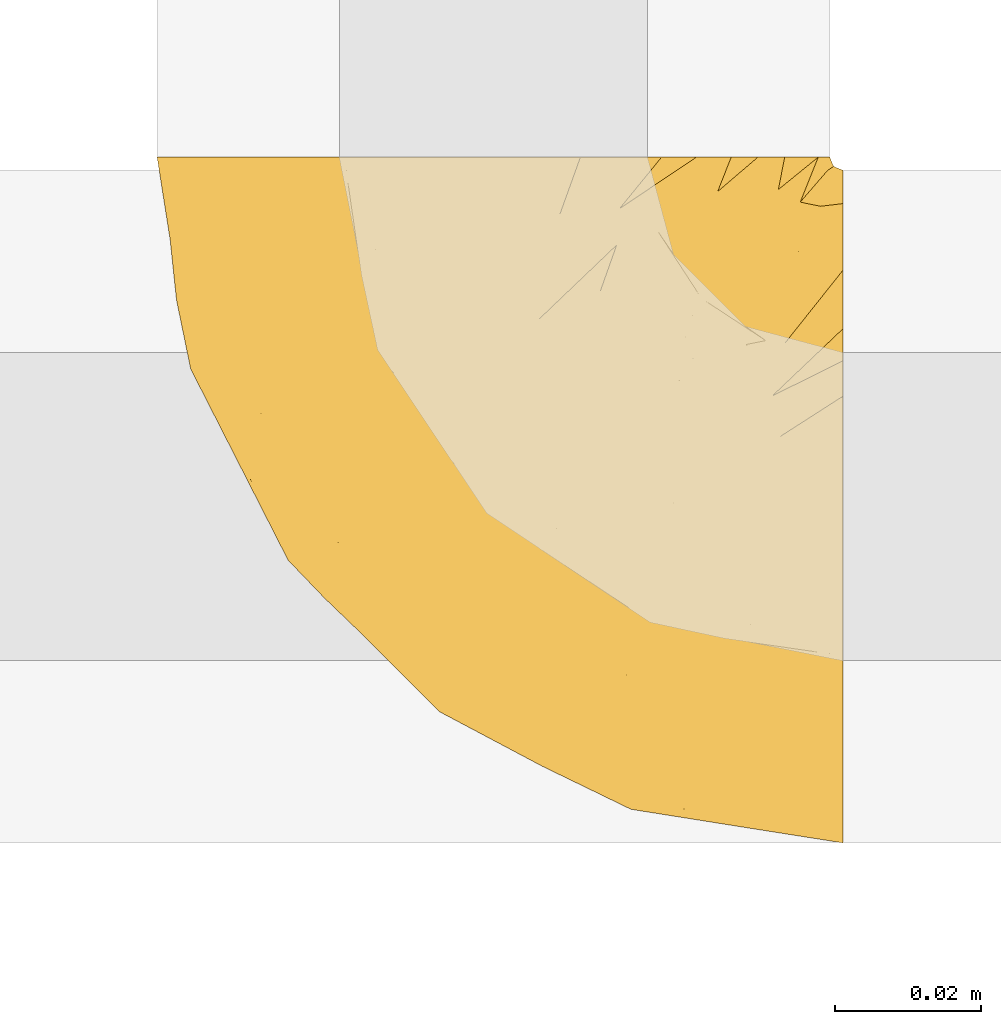
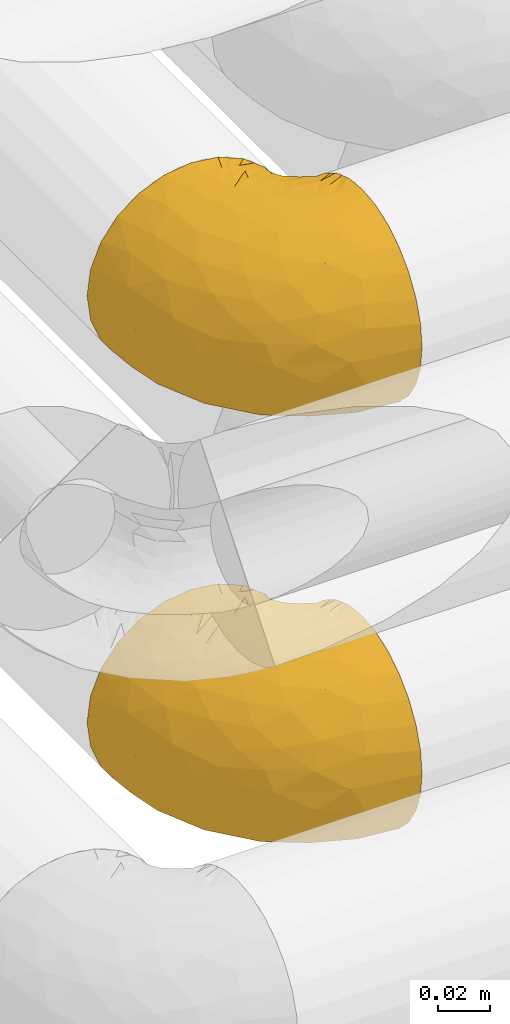
# One storey, part 144 of 827: 2 coverings.
"""IFC2X3 building model written with IfcOpenShell, lengths in millimetres."""

import ifcopenshell
import ifcopenshell.guid

model = None  # the IFC model being written
_history = None  # IfcOwnerHistory: only IFC2X3 demands one
_inside = {}  # id of a spatial element -> (the spatial element, [elements in it])
_under = {}  # id of a project, library or spatial element -> (it, [spatial elements below it])
_declared = {}  # id of a project -> (the project, [libraries it declares])
_typed = {}  # id of a type object -> (the type object, [elements of that type])
_made_of = {}  # id of a material, layer set ... -> (it, [elements and type objects made of it])


def new_model(schema):
    """Start an empty IFC model of exactly this schema.

    Asked for "IFC4X3", IfcOpenShell would pick the latest addendum, in which some entities
    have other attributes; the version numbers below select the first issue.
    IFC2X3 requires an IfcOwnerHistory on every rooted entity: one is made here for all.
    """
    global model, _history
    if schema == "IFC4X3":
        model = ifcopenshell.file(schema_version=(4, 3, 0, 0))
    else:
        model = ifcopenshell.file(schema=schema)
    _inside.clear()
    _under.clear()
    _declared.clear()
    _typed.clear()
    _made_of.clear()
    _history = None
    if model.schema == "IFC2X3":
        org = make("IfcOrganization", Name="unknown")
        user = make(
            "IfcPersonAndOrganization",
            ThePerson=make("IfcPerson", FamilyName="unknown"),
            TheOrganization=org,
        )
        app = make(
            "IfcApplication",
            ApplicationDeveloper=org,
            Version="unknown",
            ApplicationFullName="unknown",
            ApplicationIdentifier="unknown",
        )
        _history = make(
            "IfcOwnerHistory",
            OwningUser=user,
            OwningApplication=app,
            ChangeAction="ADDED",
            CreationDate=0,
        )
    return model


def make(cls, **values):
    """One entity of the class cls with the attributes given. An attribute that is None is left unset."""
    return model.create_entity(
        cls, **{name: value for name, value in values.items() if value is not None}
    )


def entity(cls, *values):
    """Any entity or typed value of the class cls, its attributes in the order of the schema. None: left unset."""
    e = model.create_entity(cls)
    for i, value in enumerate(values):
        if value is not None:
            e[i] = value
    return e


def rooted(cls, **values):
    """An entity with a GlobalId (a new one), such as an element, a storey or a relation."""
    return make(cls, GlobalId=ifcopenshell.guid.new(), OwnerHistory=_history, **values)


def si_unit(unit_type, name, prefix=None):
    """IfcSIUnit, for example si_unit("LENGTHUNIT", "METRE", prefix="MILLI")."""
    return make("IfcSIUnit", UnitType=unit_type, Prefix=prefix, Name=name)


def converted_unit(unit_type, name, factor, base, dimensions=None, offset=None):
    """IfcConversionBasedUnit, such as the inch: factor (a typed value) times the base unit."""
    return make(
        "IfcConversionBasedUnit"
        if offset is None
        else "IfcConversionBasedUnitWithOffset",
        ConversionOffset=offset,
        Dimensions=None
        if dimensions is None
        else entity("IfcDimensionalExponents", *dimensions),
        UnitType=unit_type,
        Name=name,
        ConversionFactor=make(
            "IfcMeasureWithUnit", ValueComponent=factor, UnitComponent=base
        ),
    )


def derived_unit(unit_type, elements):
    """IfcDerivedUnit: a product of units, each with its exponent."""
    return make(
        "IfcDerivedUnit",
        Elements=[
            make("IfcDerivedUnitElement", Unit=unit, Exponent=power)
            for unit, power in elements
        ],
        UnitType=unit_type,
    )


def assignment(units):
    """IfcUnitAssignment: the units of a project."""
    return None if units is None else make("IfcUnitAssignment", Units=units)


def point(xyz):
    """IfcCartesianPoint."""
    return None if xyz is None else make("IfcCartesianPoint", Coordinates=xyz)


def direction(xyz):
    """IfcDirection."""
    return None if xyz is None else make("IfcDirection", DirectionRatios=xyz)


def frame(location, z_axis=None, x_axis=None):
    """IfcAxis2Placement3D, a coordinate frame: its origin and axes. An axis left out is left unset."""
    return make(
        "IfcAxis2Placement3D",
        Location=point(location),
        Axis=direction(z_axis),
        RefDirection=direction(x_axis),
    )


def origin():
    """The frame at (0, 0, 0) with its axes left unset."""
    return frame((0.0, 0.0, 0.0))


def place(relative_to, where):
    """IfcLocalPlacement: puts the frame where relative to a parent placement (None: the world)."""
    return make(
        "IfcLocalPlacement", PlacementRelTo=relative_to, RelativePlacement=where
    )


def context(
    kind, dimensions, precision=None, world=None, true_north=None, identifier=None
):
    """IfcGeometricRepresentationContext, for example the 3D "Model" context."""
    return make(
        "IfcGeometricRepresentationContext",
        ContextIdentifier=identifier,
        ContextType=kind,
        CoordinateSpaceDimension=dimensions,
        Precision=precision,
        WorldCoordinateSystem=world,
        TrueNorth=true_north,
    )


def subcontext(parent, identifier, kind, view, scale=None):
    """IfcGeometricRepresentationSubContext, for example "Body" below "Model"."""
    return make(
        "IfcGeometricRepresentationSubContext",
        ContextIdentifier=identifier,
        ContextType=kind,
        ParentContext=parent,
        TargetScale=scale,
        TargetView=view,
    )


def project(units=None, contexts=None):
    """IfcProject with its units and contexts."""
    return rooted(
        "IfcProject",
        Name="project",
        RepresentationContexts=contexts,
        UnitsInContext=assignment(units),
    )


def spatial(cls, under=None, at=None, **own):
    """A site, building, storey or space (cls), placed at a placement, below another one or the project."""
    s = rooted(cls, ObjectPlacement=at, **own)
    if under is not None:
        _under.setdefault(under.id(), (under, []))[1].append(s)
    return s


def faces_of(points, faces, orient=None, outer=None):
    """IfcFace entities. A face is a list of loops; a loop is a list of indices into points, from 0.

    orient and outer hold one flag for each loop. By default every Orientation is true, the
    first loop of a face is its IfcFaceOuterBound and the others are IfcFaceBound.
    """
    made = []
    for i, loops in enumerate(faces):
        bounds = []
        for j, loop in enumerate(loops):
            is_outer = j == 0 if outer is None else outer[i][j]
            bounds.append(
                make(
                    "IfcFaceOuterBound" if is_outer else "IfcFaceBound",
                    Bound=make("IfcPolyLoop", Polygon=[points[k] for k in loop]),
                    Orientation=True if orient is None else orient[i][j],
                )
            )
        made.append(make("IfcFace", Bounds=bounds))
    return made


def faceted_brep(points, faces, orient=None, outer=None, voids=None):
    """IfcFacetedBrep: a solid bounded by flat faces; with voids (closed shells), ...WithVoids."""
    shared = [point(p) for p in points]
    hull = make("IfcClosedShell", CfsFaces=faces_of(shared, faces, orient, outer))
    if voids is None:
        return make("IfcFacetedBrep", Outer=hull)
    return make(
        "IfcFacetedBrepWithVoids",
        Outer=hull,
        Voids=[
            make(cls, CfsFaces=faces_of(shared, fs, o, b)) for cls, fs, o, b in voids
        ],
    )


def shape(context_of_items, identifier, shape_type, items):
    """IfcShapeRepresentation: the items that make up one representation, for example the "Body"."""
    return make(
        "IfcShapeRepresentation",
        ContextOfItems=context_of_items,
        RepresentationIdentifier=identifier,
        RepresentationType=shape_type,
        Items=items,
    )


def made_of(thing, what):
    """Note that an element or type object is made of a material, layer set ...; save() writes the relation."""
    if what is not None:
        _made_of.setdefault(what.id(), (what, []))[1].append(thing)
    return thing


def element(
    cls,
    number,
    at=None,
    inside=None,
    cuts=None,
    type_object=None,
    material=None,
    context=None,
    identifier="Body",
    shape_type=None,
    held_by="IfcProductDefinitionShape",
    body=None,
    shapes=None,
    **own,
):
    """One element of the class cls, such as IfcWall. Its Tag is "e" and its number.

    at: its placement. inside: the storey or other place that contains it. cuts: it is an
    opening in that element (IfcRelVoidsElement). A single representation is given by context,
    identifier, shape_type and body (its items); several are given by shapes. held_by: the class
    of the entity that holds the representations. save() writes the other relations.
    """
    e = rooted(cls, Tag="e%d" % number, ObjectPlacement=at, **own)
    if body is not None:
        shapes = [shape(context, identifier, shape_type, body)]
    if shapes is not None:
        e.Representation = make(held_by, Representations=shapes)
    if inside is not None:
        _inside.setdefault(inside.id(), (inside, []))[1].append(e)
    if cuts is not None:
        rooted(
            "IfcRelVoidsElement", RelatingBuildingElement=cuts, RelatedOpeningElement=e
        )
    if type_object is not None:
        _typed.setdefault(type_object.id(), (type_object, []))[1].append(e)
    return made_of(e, material)


def aggregate(whole, parts):
    """IfcRelAggregates: a whole, such as a stair, and the parts it consists of."""
    return rooted("IfcRelAggregates", RelatingObject=whole, RelatedObjects=parts)


def save(model, path):
    """Write the relations noted so far, then the file.

    IfcRelAggregates (storeys below a building ...), IfcRelContainedInSpatialStructure (elements
    in a storey), IfcRelDefinesByType, IfcRelAssociatesMaterial and IfcRelDeclares: one each for
    every whole, place, type object, material and project.
    """
    for whole, parts in _under.values():
        aggregate(whole, parts)
    for where, things in _inside.values():
        rooted(
            "IfcRelContainedInSpatialStructure",
            RelatedElements=things,
            RelatingStructure=where,
        )
    for kind, things in _typed.values():
        rooted("IfcRelDefinesByType", RelatedObjects=things, RelatingType=kind)
    for what, things in _made_of.values():
        rooted("IfcRelAssociatesMaterial", RelatedObjects=things, RelatingMaterial=what)
    for by, libraries in _declared.values():
        rooted("IfcRelDeclares", RelatingContext=by, RelatedDefinitions=libraries)
    model.write(path)


model = new_model("IFC2X3")

# Units and contexts
model_context = context("Model", 3, precision=0.01, world=origin(), true_north=direction((6.12303176911189e-17, 1.0)))
body_context = subcontext(model_context, "Body", "Model", "MODEL_VIEW")
ifc_project = project(units=[si_unit("LENGTHUNIT", "METRE", prefix="MILLI"), si_unit("AREAUNIT", "SQUARE_METRE"), si_unit("VOLUMEUNIT", "CUBIC_METRE"), converted_unit("PLANEANGLEUNIT", "DEGREE", entity("IfcRatioMeasure", 0.0174532925199433), si_unit("PLANEANGLEUNIT", "RADIAN"), dimensions=[0, 0, 0, 0, 0, 0, 0]), si_unit("MASSUNIT", "GRAM", prefix="KILO"), derived_unit("MASSDENSITYUNIT", [(si_unit("MASSUNIT", "GRAM", prefix="KILO"), 1), (si_unit("LENGTHUNIT", "METRE"), -3)]), derived_unit("MOMENTOFINERTIAUNIT", [(si_unit("LENGTHUNIT", "METRE"), 4)]), si_unit("TIMEUNIT", "SECOND"), si_unit("FREQUENCYUNIT", "HERTZ"), si_unit("THERMODYNAMICTEMPERATUREUNIT", "DEGREE_CELSIUS"), derived_unit("THERMALTRANSMITTANCEUNIT", [(si_unit("MASSUNIT", "GRAM", prefix="KILO"), 1), (si_unit("THERMODYNAMICTEMPERATUREUNIT", "KELVIN"), -1), (si_unit("TIMEUNIT", "SECOND"), -3)]), derived_unit("VOLUMETRICFLOWRATEUNIT", [(si_unit("LENGTHUNIT", "METRE"), 3), (si_unit("TIMEUNIT", "SECOND"), -1)]), derived_unit("MASSFLOWRATEUNIT", [(si_unit("MASSUNIT", "GRAM", prefix="KILO"), 1), (si_unit("TIMEUNIT", "SECOND"), -1)]), derived_unit("ROTATIONALFREQUENCYUNIT", [(si_unit("TIMEUNIT", "SECOND"), -1)]), si_unit("ELECTRICCURRENTUNIT", "AMPERE"), si_unit("ELECTRICVOLTAGEUNIT", "VOLT"), si_unit("POWERUNIT", "WATT"), si_unit("FORCEUNIT", "NEWTON", prefix="KILO"), si_unit("ILLUMINANCEUNIT", "LUX"), si_unit("LUMINOUSFLUXUNIT", "LUMEN"), si_unit("LUMINOUSINTENSITYUNIT", "CANDELA"), derived_unit("USERDEFINED", [(si_unit("MASSUNIT", "GRAM", prefix="KILO"), -1), (si_unit("LENGTHUNIT", "METRE"), -2), (si_unit("TIMEUNIT", "SECOND"), 3), (si_unit("LUMINOUSFLUXUNIT", "LUMEN"), 1)]), derived_unit("LINEARVELOCITYUNIT", [(si_unit("LENGTHUNIT", "METRE"), 1), (si_unit("TIMEUNIT", "SECOND"), -1)]), si_unit("PRESSUREUNIT", "PASCAL"), derived_unit("USERDEFINED", [(si_unit("LENGTHUNIT", "METRE"), -2), (si_unit("MASSUNIT", "GRAM", prefix="KILO"), 1), (si_unit("TIMEUNIT", "SECOND"), -2)]), derived_unit("LINEARFORCEUNIT", [(si_unit("MASSUNIT", "GRAM", prefix="KILO"), 1), (si_unit("LENGTHUNIT", "METRE"), 1), (si_unit("TIMEUNIT", "SECOND"), -2), (si_unit("LENGTHUNIT", "METRE"), -1)]), derived_unit("PLANARFORCEUNIT", [(si_unit("MASSUNIT", "GRAM", prefix="KILO"), 1), (si_unit("LENGTHUNIT", "METRE"), 1), (si_unit("TIMEUNIT", "SECOND"), -2), (si_unit("LENGTHUNIT", "METRE"), -2)])], contexts=[model_context])

# Site, building, storey
site_placement = place(None, origin())
site = spatial("IfcSite", under=ifc_project, at=site_placement, CompositionType="ELEMENT")
building_placement = place(site_placement, origin())
building = spatial("IfcBuilding", under=site, at=building_placement, CompositionType="ELEMENT")
storey_placement = place(building_placement, frame((0.0, 0.0, 28200.0)))
storey = spatial("IfcBuildingStorey", under=building, at=storey_placement, Name="08", CompositionType="ELEMENT", Elevation=28200.0)

# Coverings
covering_1_placement = place(storey_placement, frame((30998.73, 14182.21, 3152.2)))
element("IfcCovering", 1, at=covering_1_placement, inside=storey, Name=":ADSK_", ObjectType=":ADSK_", PredefinedType="INSULATION", context=body_context, shape_type="Brep", body=[
    faceted_brep([(95.8, 37.51, 92.84), (95.8, 27.74, 89.42), (95.8, 18.98, 83.91), (95.8, 11.67, 76.59), (95.8, 6.17, 67.83), (95.8, 2.75, 58.07), (95.8, 1.6, 47.8), (95.8, 2.75, 37.51), (95.8, 6.17, 27.74), (95.8, 11.68, 18.98), (95.8, 19.0, 11.67), (95.8, 27.76, 6.17), (95.8, 37.52, 2.75), (95.8, 47.8, 1.6), (95.8, 51.94, 2.06), (95.8, 55.01, 2.41), (95.8, 58.08, 2.75), (95.8, 62.96, 4.46), (95.8, 67.85, 6.17), (95.8, 72.23, 8.93), (95.8, 76.61, 11.68), (95.8, 80.26, 15.34), (95.8, 83.92, 19.0), (95.8, 89.42, 27.76), (95.8, 91.13, 32.64), (95.8, 92.84, 37.52), (95.8, 94.0, 47.8), (95.8, 92.84, 58.08), (95.8, 91.13, 62.96), (95.8, 89.42, 67.85), (95.8, 83.91, 76.61), (95.8, 80.25, 80.26), (95.8, 76.59, 83.92), (95.8, 72.21, 86.67), (95.8, 67.83, 89.42), (95.8, 62.95, 91.13), (95.8, 58.07, 92.84), (95.8, 55.0, 93.18), (95.8, 51.94, 93.53), (95.8, 47.8, 94.0), (94.0, 95.8, 47.8), (92.42, 95.8, 35.84), (87.81, 95.8, 24.7), (84.13, 95.8, 19.91), (80.46, 95.8, 15.13), (75.68, 95.8, 11.46), (70.9, 95.8, 7.78), (65.32, 95.8, 5.48), (59.75, 95.8, 3.17), (56.14, 95.8, 2.69), (54.06, 95.8, 2.42), (51.97, 95.8, 2.14), (47.8, 95.8, 1.6), (35.84, 95.8, 3.17), (24.7, 95.8, 7.78), (15.13, 95.8, 15.13), (7.78, 95.8, 24.7), (3.17, 95.8, 35.84), (1.6, 95.8, 47.8), (3.17, 95.8, 59.75), (7.78, 95.8, 70.9), (15.13, 95.8, 80.46), (24.7, 95.8, 87.81), (35.84, 95.8, 92.42), (47.8, 95.8, 94.0), (51.97, 95.8, 93.45), (56.14, 95.8, 92.9), (59.75, 95.8, 92.42), (65.32, 95.8, 90.11), (70.9, 95.8, 87.81), (75.68, 95.8, 84.13), (80.46, 95.8, 80.46), (84.13, 95.8, 75.68), (87.81, 95.8, 70.9), (92.42, 95.8, 59.75), (15.84, 60.58, 71.98), (6.99, 74.11, 63.6), (14.39, 51.59, 59.72), (6.21, 66.69, 47.8), (4.26, 76.19, 55.16), (3.39, 84.43, 47.8), (31.2, 31.2, 63.76), (26.47, 42.88, 72.22), (11.44, 79.41, 74.18), (47.66, 60.7, 92.52), (61.85, 61.85, 94.0), (59.25, 65.75, 94.0), (56.65, 69.64, 94.0), (54.05, 73.53, 94.0), (51.45, 77.43, 94.0), (19.8, 74.59, 82.14), (26.22, 54.72, 80.34), (31.58, 64.18, 87.52), (38.36, 37.94, 79.59), (51.54, 25.89, 78.25), (51.6, 34.73, 85.01), (55.97, 42.89, 90.25), (62.88, 49.83, 93.2), (41.35, 48.58, 87.23), (82.24, 22.41, 85.55), (40.88, 78.69, 93.0), (29.0, 81.64, 89.31), (74.06, 6.22, 61.31), (54.53, 12.11, 56.86), (57.98, 14.81, 68.34), (43.81, 21.61, 65.71), (38.22, 22.41, 56.99), (38.33, 30.12, 72.15), (74.76, 10.01, 70.34), (76.85, 15.36, 78.36), (84.43, 3.39, 47.8), (40.43, 19.59, 47.8), (30.01, 30.01, 47.8), (78.67, 41.19, 93.06), (92.06, 48.54, 94.0), (88.32, 49.28, 94.0), (85.6, 49.82, 94.0), (82.88, 50.37, 94.0), (80.15, 50.91, 94.0), (77.43, 51.45, 94.0), (76.36, 31.61, 89.88), (50.91, 80.15, 94.0), (50.37, 82.88, 94.0), (49.82, 85.6, 94.0), (49.28, 88.32, 94.0), (48.91, 90.19, 94.0), (48.54, 92.06, 94.0), (66.69, 6.21, 47.8), (73.53, 54.05, 94.0), (69.64, 56.65, 94.0), (65.75, 59.25, 94.0), (66.13, 24.66, 83.7), (19.59, 40.43, 47.8), (24.64, 35.17, 55.9), (53.56, 12.9, 47.8), (12.9, 53.56, 47.8), (82.81, 85.34, 81.75), (81.22, 78.44, 86.43), (86.57, 84.37, 79.8), (92.75, 89.05, 69.84), (89.68, 82.76, 79.5), (72.26, 86.31, 88.08), (64.73, 83.73, 91.6), (62.45, 77.31, 92.93), (60.63, 87.78, 92.43), (56.91, 87.91, 93.24), (58.14, 81.29, 93.36), (93.7, 93.97, 57.25), (83.4, 70.76, 89.41), (75.54, 63.67, 92.89), (79.46, 62.62, 92.66), (82.28, 90.64, 79.58), (76.25, 84.08, 86.51), (90.18, 77.45, 83.91), (87.92, 70.34, 88.76), (86.94, 91.35, 73.94), (65.12, 88.72, 90.94), (71.71, 71.28, 91.94), (75.21, 68.09, 91.98), (78.6, 91.07, 82.79), (87.27, 57.47, 93.16), (86.1, 62.99, 91.89), (94.52, 94.52, 47.8), (66.23, 76.47, 92.22), (84.69, 76.28, 86.29), (91.08, 69.96, 88.56), (71.77, 89.86, 87.72), (76.21, 78.94, 88.33), (68.59, 73.51, 92.18), (89.94, 89.62, 71.78), (76.22, 78.96, 7.27), (81.22, 78.46, 9.17), (71.7, 71.31, 3.66), (48.54, 92.06, 1.6), (50.37, 82.88, 1.6), (49.82, 85.6, 1.6), (49.28, 88.32, 1.6), (93.7, 93.97, 38.35), (89.95, 89.63, 23.84), (82.88, 50.37, 1.6), (85.6, 49.82, 1.6), (92.06, 48.54, 1.6), (88.32, 49.28, 1.6), (89.68, 82.77, 16.1), (87.92, 70.36, 6.84), (62.45, 77.31, 2.66), (66.24, 76.47, 3.37), (56.65, 69.64, 1.6), (59.25, 65.75, 1.6), (78.6, 91.06, 12.8), (60.63, 87.78, 3.16), (56.91, 87.91, 2.35), (92.76, 89.06, 25.77), (76.25, 84.09, 9.09), (82.28, 90.65, 16.02), (82.81, 85.35, 13.85), (54.05, 73.53, 1.6), (51.45, 77.43, 1.6), (58.14, 81.29, 2.23), (90.18, 77.46, 11.69), (84.7, 76.29, 9.31), (87.25, 57.47, 2.43), (75.58, 63.71, 2.71), (75.2, 68.11, 3.61), (83.39, 70.77, 6.18), (90.73, 69.52, 6.77), (79.47, 62.64, 2.93), (86.94, 91.35, 21.66), (65.75, 59.25, 1.6), (86.75, 84.6, 16.09), (86.08, 62.98, 3.7), (77.43, 51.45, 1.6), (73.53, 54.05, 1.6), (69.64, 56.65, 1.6), (64.73, 83.73, 3.99), (50.91, 80.15, 1.6), (65.12, 88.72, 4.65), (72.26, 86.3, 7.51), (61.85, 61.85, 1.6), (68.62, 73.56, 3.43), (74.03, 91.36, 9.46), (80.15, 50.91, 1.6), (49.81, 62.87, 2.4), (4.26, 76.19, 40.43), (19.95, 73.57, 13.57), (30.61, 56.07, 11.3), (25.71, 49.77, 18.65), (22.43, 44.73, 27.26), (15.85, 60.58, 23.61), (60.69, 47.64, 3.07), (40.49, 78.32, 2.69), (14.39, 51.59, 35.87), (6.99, 74.11, 31.99), (29.56, 76.04, 6.71), (11.45, 79.41, 21.41), (57.98, 14.82, 27.24), (74.06, 6.22, 34.26), (54.52, 12.12, 38.73), (43.47, 23.51, 26.97), (31.2, 31.2, 31.83), (33.27, 34.96, 23.4), (64.26, 33.86, 6.91), (74.29, 38.94, 3.4), (80.41, 30.23, 5.84), (41.67, 20.67, 35.73), (24.64, 35.17, 39.69), (73.62, 15.85, 17.6), (78.98, 22.59, 10.38), (53.69, 21.56, 20.6), (42.86, 55.94, 5.36), (79.66, 9.19, 24.84), (58.41, 25.79, 13.87), (47.11, 41.16, 9.06), (38.37, 37.95, 15.99)], [[[0, 1, 2, 3, 4, 5, 6, 7, 8, 9, 10, 11, 12, 13, 14, 15, 16, 17, 18, 19, 20, 21, 22, 23, 24, 25, 26, 27, 28, 29, 30, 31, 32, 33, 34, 35, 36, 37, 38, 39]], [[40, 41, 42, 43, 44, 45, 46, 47, 48, 49, 50, 51, 52, 53, 54, 55, 56, 57, 58, 59, 60, 61, 62, 63, 64, 65, 66, 67, 68, 69, 70, 71, 72, 73, 74]], [[75, 76, 77]], [[78, 79, 80]], [[77, 81, 82]], [[76, 75, 83]], [[84, 85, 86, 87, 88, 89]], [[90, 91, 92]], [[76, 60, 59]], [[93, 94, 95]], [[90, 62, 61]], [[83, 61, 60]], [[96, 97, 84]], [[98, 93, 95]], [[2, 1, 99]], [[100, 84, 89]], [[62, 101, 63]], [[4, 102, 5]], [[92, 84, 100]], [[103, 102, 104]], [[103, 105, 106]], [[93, 107, 94]], [[3, 108, 4]], [[92, 101, 90]], [[108, 3, 109]], [[102, 110, 5]], [[93, 82, 107]], [[102, 108, 104]], [[111, 106, 112]], [[109, 2, 99]], [[113, 39, 114, 115, 116, 117, 118, 119]], [[120, 0, 113]], [[100, 89, 121, 122, 123, 124, 125, 126, 64]], [[127, 102, 103]], [[97, 119, 128, 129, 130, 85]], [[99, 120, 131]], [[132, 133, 77]], [[59, 80, 79]], [[3, 2, 109]], [[98, 84, 92]], [[94, 109, 131]], [[120, 1, 0]], [[93, 91, 82]], [[104, 94, 105]], [[97, 113, 119]], [[95, 120, 96]], [[83, 90, 61]], [[91, 93, 98]], [[64, 63, 100]], [[100, 63, 101]], [[77, 76, 79]], [[133, 106, 81]], [[84, 97, 85]], [[113, 96, 120]], [[113, 97, 96]], [[39, 113, 0]], [[110, 102, 127]], [[110, 6, 5]], [[103, 111, 134, 127]], [[90, 75, 91]], [[82, 81, 107]], [[91, 75, 82]], [[77, 82, 75]], [[76, 83, 60]], [[90, 83, 75]], [[105, 107, 81]], [[94, 131, 95]], [[105, 94, 107]], [[109, 94, 104]], [[120, 95, 131]], [[98, 95, 96]], [[84, 98, 96]], [[98, 92, 91]], [[106, 105, 81]], [[103, 104, 105]], [[133, 132, 112]], [[103, 106, 111]], [[77, 78, 135, 132]], [[81, 77, 133]], [[106, 133, 112]], [[120, 99, 1]], [[109, 99, 131]], [[59, 58, 80]], [[59, 79, 76]], [[90, 101, 62]], [[100, 101, 92]], [[4, 108, 102]], [[109, 104, 108]], [[78, 77, 79]], [[136, 137, 138]], [[29, 139, 140]], [[141, 142, 143]], [[144, 145, 121]], [[146, 89, 88]], [[147, 139, 27]], [[148, 149, 150]], [[136, 151, 152]], [[147, 40, 74]], [[26, 147, 27]], [[153, 148, 154]], [[35, 116, 36]], [[73, 151, 155]], [[114, 39, 38, 37, 36, 116, 115]], [[146, 156, 144]], [[157, 85, 130]], [[158, 149, 148]], [[151, 159, 152]], [[117, 35, 160]], [[31, 153, 154]], [[155, 74, 73]], [[161, 128, 119]], [[65, 64, 126, 125, 124, 123, 122, 67, 66]], [[162, 147, 26]], [[29, 140, 30]], [[149, 129, 150]], [[139, 29, 28, 27]], [[68, 144, 69]], [[129, 128, 150]], [[163, 87, 86]], [[130, 129, 149]], [[122, 145, 67]], [[153, 164, 148]], [[161, 119, 160]], [[165, 32, 154]], [[150, 154, 148]], [[128, 161, 150]], [[32, 165, 33]], [[145, 144, 68]], [[89, 146, 144]], [[87, 163, 143]], [[166, 156, 142]], [[88, 87, 143]], [[161, 154, 150]], [[154, 32, 31]], [[31, 30, 153]], [[30, 140, 153]], [[164, 153, 140]], [[140, 137, 164]], [[158, 148, 164]], [[157, 130, 158]], [[164, 137, 158]], [[158, 137, 157]], [[167, 137, 136]], [[168, 85, 157]], [[152, 168, 167]], [[167, 168, 157]], [[163, 152, 141]], [[151, 73, 72]], [[159, 72, 71]], [[88, 142, 146]], [[144, 156, 69]], [[146, 142, 156]], [[70, 166, 71]], [[142, 141, 166]], [[70, 69, 156]], [[141, 159, 71]], [[167, 136, 152]], [[138, 137, 140]], [[155, 136, 169]], [[136, 155, 151]], [[74, 155, 169]], [[152, 159, 141]], [[151, 72, 159]], [[168, 152, 163]], [[137, 167, 157]], [[163, 86, 168]], [[85, 168, 86]], [[116, 35, 117]], [[130, 149, 158]], [[67, 145, 68]], [[121, 89, 144]], [[145, 122, 121]], [[40, 147, 162]], [[169, 147, 74]], [[160, 35, 34]], [[161, 160, 34]], [[160, 119, 118, 117]], [[139, 147, 169]], [[139, 169, 138]], [[161, 34, 33]], [[141, 143, 163]], [[88, 143, 142]], [[71, 166, 141]], [[156, 166, 70]], [[139, 138, 140]], [[169, 136, 138]], [[154, 161, 165]], [[161, 33, 165]], [[170, 171, 172]], [[173, 52, 51, 50, 49, 48, 174, 175, 176]], [[177, 178, 41]], [[179, 17, 180]], [[14, 13, 181, 182, 180, 16, 15]], [[183, 23, 22]], [[21, 20, 184]], [[185, 186, 187]], [[186, 188, 187]], [[43, 189, 44]], [[190, 191, 47]], [[25, 24, 23, 192]], [[193, 194, 195]], [[40, 162, 177]], [[196, 197, 198]], [[26, 25, 177]], [[199, 200, 183]], [[201, 17, 179]], [[47, 46, 190]], [[202, 203, 204]], [[203, 172, 171]], [[205, 206, 184]], [[207, 41, 178]], [[18, 17, 201]], [[16, 180, 17]], [[204, 203, 200]], [[208, 203, 202]], [[162, 26, 177]], [[48, 47, 191]], [[198, 197, 190]], [[199, 184, 204]], [[171, 195, 209]], [[210, 211, 212]], [[206, 212, 213]], [[205, 19, 210]], [[184, 206, 204]], [[210, 212, 206]], [[185, 196, 214]], [[190, 215, 191]], [[216, 45, 214]], [[186, 217, 193]], [[190, 216, 198]], [[199, 22, 21]], [[196, 185, 187]], [[199, 183, 22]], [[184, 199, 21]], [[199, 204, 200]], [[206, 202, 204]], [[171, 183, 200]], [[203, 208, 172]], [[172, 208, 218]], [[171, 200, 203]], [[218, 188, 219]], [[195, 170, 193]], [[217, 186, 185]], [[193, 219, 186]], [[193, 170, 219]], [[207, 194, 42]], [[217, 220, 189]], [[216, 190, 46]], [[214, 196, 198]], [[44, 220, 45]], [[214, 198, 216]], [[216, 46, 45]], [[214, 45, 220]], [[42, 194, 43]], [[189, 193, 217]], [[207, 195, 194]], [[209, 195, 178]], [[41, 207, 42]], [[195, 207, 178]], [[43, 194, 189]], [[193, 189, 194]], [[171, 170, 195]], [[170, 172, 219]], [[218, 219, 172]], [[188, 186, 219]], [[206, 213, 202]], [[208, 202, 213]], [[201, 210, 18]], [[215, 190, 197]], [[215, 174, 191]], [[174, 48, 191]], [[201, 179, 221, 211]], [[210, 201, 211]], [[25, 192, 177]], [[40, 177, 41]], [[178, 177, 192]], [[23, 183, 192]], [[209, 192, 183]], [[205, 20, 19]], [[19, 18, 210]], [[217, 185, 214]], [[189, 220, 44]], [[214, 220, 217]], [[192, 209, 178]], [[171, 209, 183]], [[206, 205, 210]], [[20, 205, 184]], [[222, 197, 196, 187, 188, 218]], [[57, 223, 80]], [[224, 225, 226]], [[226, 227, 228]], [[229, 218, 208, 213, 212, 211]], [[230, 52, 173, 176, 175, 174, 215, 197]], [[231, 232, 228]], [[231, 78, 223]], [[223, 57, 232]], [[224, 233, 225]], [[233, 54, 53]], [[234, 232, 56]], [[56, 55, 234]], [[234, 224, 228]], [[235, 236, 237]], [[224, 55, 54]], [[238, 239, 240]], [[52, 230, 53]], [[241, 242, 243]], [[239, 244, 245]], [[13, 12, 242]], [[236, 8, 7]], [[9, 246, 10]], [[10, 247, 11]], [[238, 248, 235]], [[222, 229, 249]], [[242, 211, 221, 179, 180, 182, 181, 13]], [[233, 53, 230]], [[111, 112, 244]], [[250, 8, 236]], [[247, 251, 241]], [[8, 250, 9]], [[127, 236, 110]], [[249, 229, 252]], [[247, 10, 246]], [[235, 246, 250]], [[236, 7, 110]], [[235, 244, 238]], [[237, 236, 127]], [[243, 11, 247]], [[252, 229, 241]], [[56, 232, 57]], [[222, 230, 197]], [[225, 249, 252]], [[249, 233, 230]], [[54, 233, 224]], [[231, 228, 227]], [[245, 132, 231]], [[249, 225, 233]], [[226, 225, 253]], [[235, 250, 236]], [[246, 9, 250]], [[251, 247, 246]], [[243, 247, 241]], [[248, 246, 235]], [[252, 251, 253]], [[229, 222, 218]], [[230, 222, 249]], [[7, 6, 110]], [[237, 127, 134, 111]], [[238, 244, 239]], [[224, 234, 55]], [[232, 234, 228]], [[242, 241, 229]], [[12, 11, 243]], [[211, 242, 229]], [[12, 243, 242]], [[80, 223, 78]], [[80, 58, 57]], [[231, 223, 232]], [[227, 240, 239]], [[224, 226, 228]], [[240, 226, 253]], [[227, 239, 245]], [[226, 240, 227]], [[251, 248, 253]], [[240, 253, 248]], [[244, 235, 237]], [[237, 111, 244]], [[132, 245, 112]], [[112, 245, 244]], [[135, 78, 231, 132]], [[227, 245, 231]], [[248, 238, 240]], [[246, 248, 251]], [[251, 252, 241]], [[225, 252, 253]]]),
])
covering_2_placement = place(storey_placement, frame((30998.73, 14182.21, 2952.2)))
element("IfcCovering", 2, at=covering_2_placement, inside=storey, Name=":ADSK_", ObjectType=":ADSK_", PredefinedType="INSULATION", context=body_context, shape_type="Brep", body=[
    faceted_brep([(95.8, 37.51, 92.84), (95.8, 27.74, 89.42), (95.8, 18.98, 83.91), (95.8, 11.67, 76.59), (95.8, 6.17, 67.83), (95.8, 2.75, 58.07), (95.8, 1.6, 47.8), (95.8, 2.75, 37.51), (95.8, 6.17, 27.74), (95.8, 11.68, 18.98), (95.8, 19.0, 11.67), (95.8, 27.76, 6.17), (95.8, 37.52, 2.75), (95.8, 47.8, 1.6), (95.8, 51.94, 2.06), (95.8, 55.01, 2.41), (95.8, 58.08, 2.75), (95.8, 62.96, 4.46), (95.8, 67.85, 6.17), (95.8, 72.23, 8.93), (95.8, 76.61, 11.68), (95.8, 80.26, 15.34), (95.8, 83.92, 19.0), (95.8, 89.42, 27.76), (95.8, 91.13, 32.64), (95.8, 92.84, 37.52), (95.8, 94.0, 47.8), (95.8, 92.84, 58.08), (95.8, 91.13, 62.96), (95.8, 89.42, 67.85), (95.8, 83.91, 76.61), (95.8, 80.25, 80.26), (95.8, 76.59, 83.92), (95.8, 72.21, 86.67), (95.8, 67.83, 89.42), (95.8, 62.95, 91.13), (95.8, 58.07, 92.84), (95.8, 55.0, 93.18), (95.8, 51.94, 93.53), (95.8, 47.8, 94.0), (94.0, 95.8, 47.8), (92.42, 95.8, 35.84), (87.81, 95.8, 24.7), (84.13, 95.8, 19.91), (80.46, 95.8, 15.13), (75.68, 95.8, 11.46), (70.9, 95.8, 7.78), (65.32, 95.8, 5.48), (59.75, 95.8, 3.17), (56.14, 95.8, 2.69), (54.06, 95.8, 2.42), (51.97, 95.8, 2.14), (47.8, 95.8, 1.6), (35.84, 95.8, 3.17), (24.7, 95.8, 7.78), (15.13, 95.8, 15.13), (7.78, 95.8, 24.7), (3.17, 95.8, 35.84), (1.6, 95.8, 47.8), (3.17, 95.8, 59.75), (7.78, 95.8, 70.9), (15.13, 95.8, 80.46), (24.7, 95.8, 87.81), (35.84, 95.8, 92.42), (47.8, 95.8, 94.0), (51.97, 95.8, 93.45), (56.14, 95.8, 92.9), (59.75, 95.8, 92.42), (65.32, 95.8, 90.11), (70.9, 95.8, 87.81), (75.68, 95.8, 84.13), (80.46, 95.8, 80.46), (84.13, 95.8, 75.68), (87.81, 95.8, 70.9), (92.42, 95.8, 59.75), (15.84, 60.58, 71.98), (6.99, 74.11, 63.6), (14.39, 51.59, 59.72), (6.21, 66.69, 47.8), (4.26, 76.19, 55.16), (3.39, 84.43, 47.8), (31.2, 31.2, 63.76), (26.47, 42.88, 72.22), (11.44, 79.41, 74.18), (47.66, 60.7, 92.52), (61.85, 61.85, 94.0), (59.25, 65.75, 94.0), (56.65, 69.64, 94.0), (54.05, 73.53, 94.0), (51.45, 77.43, 94.0), (19.8, 74.59, 82.14), (26.22, 54.72, 80.34), (31.58, 64.18, 87.52), (38.36, 37.94, 79.59), (51.54, 25.89, 78.25), (51.6, 34.73, 85.01), (55.97, 42.89, 90.25), (62.88, 49.83, 93.2), (41.35, 48.58, 87.23), (82.24, 22.41, 85.55), (40.88, 78.69, 93.0), (29.0, 81.64, 89.31), (74.06, 6.22, 61.31), (54.53, 12.11, 56.86), (57.98, 14.81, 68.34), (43.81, 21.61, 65.71), (38.22, 22.41, 56.99), (38.33, 30.12, 72.15), (74.76, 10.01, 70.34), (76.85, 15.36, 78.36), (84.43, 3.39, 47.8), (40.43, 19.59, 47.8), (30.01, 30.01, 47.8), (78.67, 41.19, 93.06), (92.06, 48.54, 94.0), (88.32, 49.28, 94.0), (85.6, 49.82, 94.0), (82.88, 50.37, 94.0), (80.15, 50.91, 94.0), (77.43, 51.45, 94.0), (76.36, 31.61, 89.88), (50.91, 80.15, 94.0), (50.37, 82.88, 94.0), (49.82, 85.6, 94.0), (49.28, 88.32, 94.0), (48.91, 90.19, 94.0), (48.54, 92.06, 94.0), (66.69, 6.21, 47.8), (73.53, 54.05, 94.0), (69.64, 56.65, 94.0), (65.75, 59.25, 94.0), (66.13, 24.66, 83.7), (19.59, 40.43, 47.8), (24.64, 35.17, 55.9), (53.56, 12.9, 47.8), (12.9, 53.56, 47.8), (82.81, 85.34, 81.75), (81.22, 78.44, 86.43), (86.57, 84.37, 79.8), (92.75, 89.05, 69.84), (89.68, 82.76, 79.5), (72.26, 86.31, 88.08), (64.73, 83.73, 91.6), (62.45, 77.31, 92.93), (60.63, 87.78, 92.43), (56.91, 87.91, 93.24), (58.14, 81.29, 93.36), (93.7, 93.97, 57.25), (83.4, 70.76, 89.41), (75.54, 63.67, 92.89), (79.46, 62.62, 92.66), (82.28, 90.64, 79.58), (76.25, 84.08, 86.51), (90.18, 77.45, 83.91), (87.92, 70.34, 88.76), (86.94, 91.35, 73.94), (65.12, 88.72, 90.94), (71.71, 71.28, 91.94), (75.21, 68.09, 91.98), (78.6, 91.07, 82.79), (87.27, 57.47, 93.16), (86.1, 62.99, 91.89), (94.52, 94.52, 47.8), (66.23, 76.47, 92.22), (84.69, 76.28, 86.29), (91.08, 69.96, 88.56), (71.77, 89.86, 87.72), (76.21, 78.94, 88.33), (68.59, 73.51, 92.18), (89.94, 89.62, 71.78), (76.22, 78.96, 7.27), (81.22, 78.46, 9.17), (71.7, 71.31, 3.66), (48.54, 92.06, 1.6), (50.37, 82.88, 1.6), (49.82, 85.6, 1.6), (49.28, 88.32, 1.6), (93.7, 93.97, 38.35), (89.95, 89.63, 23.84), (82.88, 50.37, 1.6), (85.6, 49.82, 1.6), (92.06, 48.54, 1.6), (88.32, 49.28, 1.6), (89.68, 82.77, 16.1), (87.92, 70.36, 6.84), (62.45, 77.31, 2.66), (66.24, 76.47, 3.37), (56.65, 69.64, 1.6), (59.25, 65.75, 1.6), (78.6, 91.06, 12.8), (60.63, 87.78, 3.16), (56.91, 87.91, 2.35), (92.76, 89.06, 25.77), (76.25, 84.09, 9.09), (82.28, 90.65, 16.02), (82.81, 85.35, 13.85), (54.05, 73.53, 1.6), (51.45, 77.43, 1.6), (58.14, 81.29, 2.23), (90.18, 77.46, 11.69), (84.7, 76.29, 9.31), (87.25, 57.47, 2.43), (75.58, 63.71, 2.71), (75.2, 68.11, 3.61), (83.39, 70.77, 6.18), (90.73, 69.52, 6.77), (79.47, 62.64, 2.93), (86.94, 91.35, 21.66), (65.75, 59.25, 1.6), (86.75, 84.6, 16.09), (86.08, 62.98, 3.7), (77.43, 51.45, 1.6), (73.53, 54.05, 1.6), (69.64, 56.65, 1.6), (64.73, 83.73, 3.99), (50.91, 80.15, 1.6), (65.12, 88.72, 4.65), (72.26, 86.3, 7.51), (61.85, 61.85, 1.6), (68.62, 73.56, 3.43), (74.03, 91.36, 9.46), (80.15, 50.91, 1.6), (49.81, 62.87, 2.4), (4.26, 76.19, 40.43), (19.95, 73.57, 13.57), (30.61, 56.07, 11.3), (25.71, 49.77, 18.65), (22.43, 44.73, 27.26), (15.85, 60.58, 23.61), (60.69, 47.64, 3.07), (40.49, 78.32, 2.69), (14.39, 51.59, 35.87), (6.99, 74.11, 31.99), (29.56, 76.04, 6.71), (11.45, 79.41, 21.41), (57.98, 14.82, 27.24), (74.06, 6.22, 34.26), (54.52, 12.12, 38.73), (43.47, 23.51, 26.97), (31.2, 31.2, 31.83), (33.27, 34.96, 23.4), (64.26, 33.86, 6.91), (74.29, 38.94, 3.4), (80.41, 30.23, 5.84), (41.67, 20.67, 35.73), (24.64, 35.17, 39.69), (73.62, 15.85, 17.6), (78.98, 22.59, 10.38), (53.69, 21.56, 20.6), (42.86, 55.94, 5.36), (79.66, 9.19, 24.84), (58.41, 25.79, 13.87), (47.11, 41.16, 9.06), (38.37, 37.95, 15.99)], [[[0, 1, 2, 3, 4, 5, 6, 7, 8, 9, 10, 11, 12, 13, 14, 15, 16, 17, 18, 19, 20, 21, 22, 23, 24, 25, 26, 27, 28, 29, 30, 31, 32, 33, 34, 35, 36, 37, 38, 39]], [[40, 41, 42, 43, 44, 45, 46, 47, 48, 49, 50, 51, 52, 53, 54, 55, 56, 57, 58, 59, 60, 61, 62, 63, 64, 65, 66, 67, 68, 69, 70, 71, 72, 73, 74]], [[75, 76, 77]], [[78, 79, 80]], [[77, 81, 82]], [[76, 75, 83]], [[84, 85, 86, 87, 88, 89]], [[90, 91, 92]], [[76, 60, 59]], [[93, 94, 95]], [[90, 62, 61]], [[83, 61, 60]], [[96, 97, 84]], [[98, 93, 95]], [[2, 1, 99]], [[100, 84, 89]], [[62, 101, 63]], [[4, 102, 5]], [[92, 84, 100]], [[103, 102, 104]], [[103, 105, 106]], [[93, 107, 94]], [[3, 108, 4]], [[92, 101, 90]], [[108, 3, 109]], [[102, 110, 5]], [[93, 82, 107]], [[102, 108, 104]], [[111, 106, 112]], [[109, 2, 99]], [[113, 39, 114, 115, 116, 117, 118, 119]], [[120, 0, 113]], [[100, 89, 121, 122, 123, 124, 125, 126, 64]], [[127, 102, 103]], [[97, 119, 128, 129, 130, 85]], [[99, 120, 131]], [[132, 133, 77]], [[59, 80, 79]], [[3, 2, 109]], [[98, 84, 92]], [[94, 109, 131]], [[120, 1, 0]], [[93, 91, 82]], [[104, 94, 105]], [[97, 113, 119]], [[95, 120, 96]], [[83, 90, 61]], [[91, 93, 98]], [[64, 63, 100]], [[100, 63, 101]], [[77, 76, 79]], [[133, 106, 81]], [[84, 97, 85]], [[113, 96, 120]], [[113, 97, 96]], [[39, 113, 0]], [[110, 102, 127]], [[110, 6, 5]], [[103, 111, 134, 127]], [[90, 75, 91]], [[82, 81, 107]], [[91, 75, 82]], [[77, 82, 75]], [[76, 83, 60]], [[90, 83, 75]], [[105, 107, 81]], [[94, 131, 95]], [[105, 94, 107]], [[109, 94, 104]], [[120, 95, 131]], [[98, 95, 96]], [[84, 98, 96]], [[98, 92, 91]], [[106, 105, 81]], [[103, 104, 105]], [[133, 132, 112]], [[103, 106, 111]], [[77, 78, 135, 132]], [[81, 77, 133]], [[106, 133, 112]], [[120, 99, 1]], [[109, 99, 131]], [[59, 58, 80]], [[59, 79, 76]], [[90, 101, 62]], [[100, 101, 92]], [[4, 108, 102]], [[109, 104, 108]], [[78, 77, 79]], [[136, 137, 138]], [[29, 139, 140]], [[141, 142, 143]], [[144, 145, 121]], [[146, 89, 88]], [[147, 139, 27]], [[148, 149, 150]], [[136, 151, 152]], [[147, 40, 74]], [[26, 147, 27]], [[153, 148, 154]], [[35, 116, 36]], [[73, 151, 155]], [[114, 39, 38, 37, 36, 116, 115]], [[146, 156, 144]], [[157, 85, 130]], [[158, 149, 148]], [[151, 159, 152]], [[117, 35, 160]], [[31, 153, 154]], [[155, 74, 73]], [[161, 128, 119]], [[65, 64, 126, 125, 124, 123, 122, 67, 66]], [[162, 147, 26]], [[29, 140, 30]], [[149, 129, 150]], [[139, 29, 28, 27]], [[68, 144, 69]], [[129, 128, 150]], [[163, 87, 86]], [[130, 129, 149]], [[122, 145, 67]], [[153, 164, 148]], [[161, 119, 160]], [[165, 32, 154]], [[150, 154, 148]], [[128, 161, 150]], [[32, 165, 33]], [[145, 144, 68]], [[89, 146, 144]], [[87, 163, 143]], [[166, 156, 142]], [[88, 87, 143]], [[161, 154, 150]], [[154, 32, 31]], [[31, 30, 153]], [[30, 140, 153]], [[164, 153, 140]], [[140, 137, 164]], [[158, 148, 164]], [[157, 130, 158]], [[164, 137, 158]], [[158, 137, 157]], [[167, 137, 136]], [[168, 85, 157]], [[152, 168, 167]], [[167, 168, 157]], [[163, 152, 141]], [[151, 73, 72]], [[159, 72, 71]], [[88, 142, 146]], [[144, 156, 69]], [[146, 142, 156]], [[70, 166, 71]], [[142, 141, 166]], [[70, 69, 156]], [[141, 159, 71]], [[167, 136, 152]], [[138, 137, 140]], [[155, 136, 169]], [[136, 155, 151]], [[74, 155, 169]], [[152, 159, 141]], [[151, 72, 159]], [[168, 152, 163]], [[137, 167, 157]], [[163, 86, 168]], [[85, 168, 86]], [[116, 35, 117]], [[130, 149, 158]], [[67, 145, 68]], [[121, 89, 144]], [[145, 122, 121]], [[40, 147, 162]], [[169, 147, 74]], [[160, 35, 34]], [[161, 160, 34]], [[160, 119, 118, 117]], [[139, 147, 169]], [[139, 169, 138]], [[161, 34, 33]], [[141, 143, 163]], [[88, 143, 142]], [[71, 166, 141]], [[156, 166, 70]], [[139, 138, 140]], [[169, 136, 138]], [[154, 161, 165]], [[161, 33, 165]], [[170, 171, 172]], [[173, 52, 51, 50, 49, 48, 174, 175, 176]], [[177, 178, 41]], [[179, 17, 180]], [[14, 13, 181, 182, 180, 16, 15]], [[183, 23, 22]], [[21, 20, 184]], [[185, 186, 187]], [[186, 188, 187]], [[43, 189, 44]], [[190, 191, 47]], [[25, 24, 23, 192]], [[193, 194, 195]], [[40, 162, 177]], [[196, 197, 198]], [[26, 25, 177]], [[199, 200, 183]], [[201, 17, 179]], [[47, 46, 190]], [[202, 203, 204]], [[203, 172, 171]], [[205, 206, 184]], [[207, 41, 178]], [[18, 17, 201]], [[16, 180, 17]], [[204, 203, 200]], [[208, 203, 202]], [[162, 26, 177]], [[48, 47, 191]], [[198, 197, 190]], [[199, 184, 204]], [[171, 195, 209]], [[210, 211, 212]], [[206, 212, 213]], [[205, 19, 210]], [[184, 206, 204]], [[210, 212, 206]], [[185, 196, 214]], [[190, 215, 191]], [[216, 45, 214]], [[186, 217, 193]], [[190, 216, 198]], [[199, 22, 21]], [[196, 185, 187]], [[199, 183, 22]], [[184, 199, 21]], [[199, 204, 200]], [[206, 202, 204]], [[171, 183, 200]], [[203, 208, 172]], [[172, 208, 218]], [[171, 200, 203]], [[218, 188, 219]], [[195, 170, 193]], [[217, 186, 185]], [[193, 219, 186]], [[193, 170, 219]], [[207, 194, 42]], [[217, 220, 189]], [[216, 190, 46]], [[214, 196, 198]], [[44, 220, 45]], [[214, 198, 216]], [[216, 46, 45]], [[214, 45, 220]], [[42, 194, 43]], [[189, 193, 217]], [[207, 195, 194]], [[209, 195, 178]], [[41, 207, 42]], [[195, 207, 178]], [[43, 194, 189]], [[193, 189, 194]], [[171, 170, 195]], [[170, 172, 219]], [[218, 219, 172]], [[188, 186, 219]], [[206, 213, 202]], [[208, 202, 213]], [[201, 210, 18]], [[215, 190, 197]], [[215, 174, 191]], [[174, 48, 191]], [[201, 179, 221, 211]], [[210, 201, 211]], [[25, 192, 177]], [[40, 177, 41]], [[178, 177, 192]], [[23, 183, 192]], [[209, 192, 183]], [[205, 20, 19]], [[19, 18, 210]], [[217, 185, 214]], [[189, 220, 44]], [[214, 220, 217]], [[192, 209, 178]], [[171, 209, 183]], [[206, 205, 210]], [[20, 205, 184]], [[222, 197, 196, 187, 188, 218]], [[57, 223, 80]], [[224, 225, 226]], [[226, 227, 228]], [[229, 218, 208, 213, 212, 211]], [[230, 52, 173, 176, 175, 174, 215, 197]], [[231, 232, 228]], [[231, 78, 223]], [[223, 57, 232]], [[224, 233, 225]], [[233, 54, 53]], [[234, 232, 56]], [[56, 55, 234]], [[234, 224, 228]], [[235, 236, 237]], [[224, 55, 54]], [[238, 239, 240]], [[52, 230, 53]], [[241, 242, 243]], [[239, 244, 245]], [[13, 12, 242]], [[236, 8, 7]], [[9, 246, 10]], [[10, 247, 11]], [[238, 248, 235]], [[222, 229, 249]], [[242, 211, 221, 179, 180, 182, 181, 13]], [[233, 53, 230]], [[111, 112, 244]], [[250, 8, 236]], [[247, 251, 241]], [[8, 250, 9]], [[127, 236, 110]], [[249, 229, 252]], [[247, 10, 246]], [[235, 246, 250]], [[236, 7, 110]], [[235, 244, 238]], [[237, 236, 127]], [[243, 11, 247]], [[252, 229, 241]], [[56, 232, 57]], [[222, 230, 197]], [[225, 249, 252]], [[249, 233, 230]], [[54, 233, 224]], [[231, 228, 227]], [[245, 132, 231]], [[249, 225, 233]], [[226, 225, 253]], [[235, 250, 236]], [[246, 9, 250]], [[251, 247, 246]], [[243, 247, 241]], [[248, 246, 235]], [[252, 251, 253]], [[229, 222, 218]], [[230, 222, 249]], [[7, 6, 110]], [[237, 127, 134, 111]], [[238, 244, 239]], [[224, 234, 55]], [[232, 234, 228]], [[242, 241, 229]], [[12, 11, 243]], [[211, 242, 229]], [[12, 243, 242]], [[80, 223, 78]], [[80, 58, 57]], [[231, 223, 232]], [[227, 240, 239]], [[224, 226, 228]], [[240, 226, 253]], [[227, 239, 245]], [[226, 240, 227]], [[251, 248, 253]], [[240, 253, 248]], [[244, 235, 237]], [[237, 111, 244]], [[132, 245, 112]], [[112, 245, 244]], [[135, 78, 231, 132]], [[227, 245, 231]], [[248, 238, 240]], [[246, 248, 251]], [[251, 252, 241]], [[225, 252, 253]]]),
])

save(model, "model.ifc")
